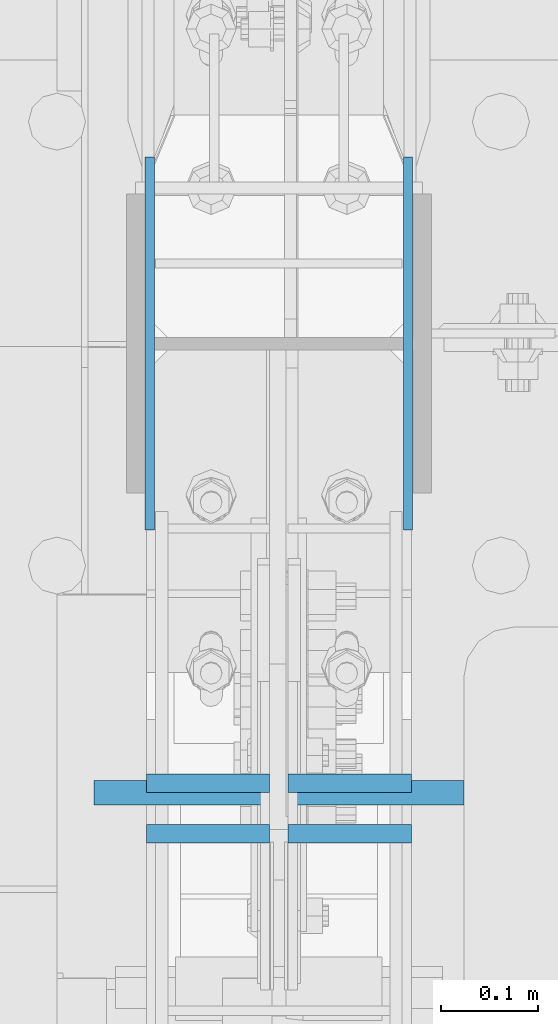
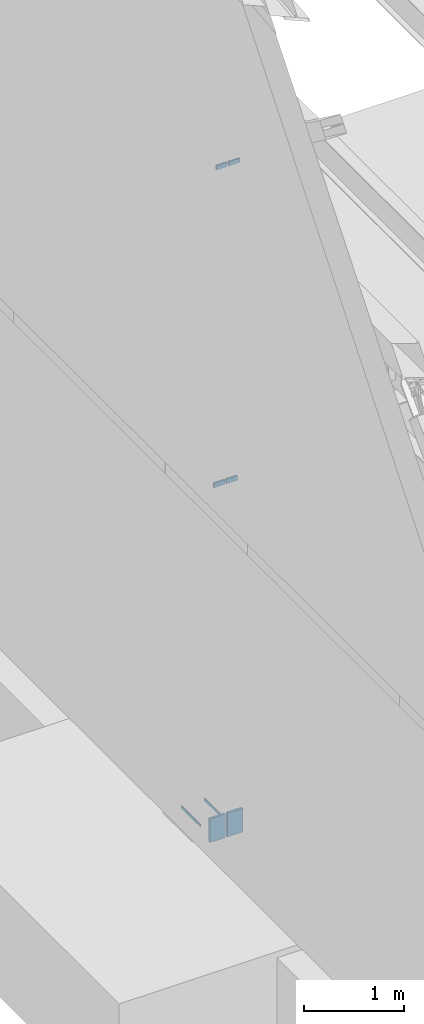
# One storey, part 418 of 1179: 8 columns, 3 elements without a shape of their own.
"""IFC2X3 building model written with IfcOpenShell, lengths in millimetres."""

from ifc_helpers import new_model, si_unit, frame, origin_with_axes, place, context, subcontext, project, spatial, faceted_brep, material, type_object, element, aggregate, save


model = new_model("IFC2X3")

# Units and contexts
model_context = context("Model", 3, precision=1e-05, world=origin_with_axes())
body_context = subcontext(model_context, "Body", "Model", "MODEL_VIEW")
ifc_project = project(units=[si_unit("LENGTHUNIT", "METRE", prefix="MILLI"), si_unit("AREAUNIT", "SQUARE_METRE"), si_unit("VOLUMEUNIT", "CUBIC_METRE"), si_unit("MASSUNIT", "GRAM", prefix="KILO"), si_unit("TIMEUNIT", "SECOND"), si_unit("PLANEANGLEUNIT", "RADIAN"), si_unit("SOLIDANGLEUNIT", "STERADIAN"), si_unit("THERMODYNAMICTEMPERATUREUNIT", "DEGREE_CELSIUS"), si_unit("LUMINOUSINTENSITYUNIT", "LUMEN")], contexts=[model_context])

# Site, building, storey
site_placement = place(None, origin_with_axes())
site = spatial("IfcSite", under=ifc_project, at=site_placement, CompositionType="ELEMENT")
building_placement = place(site_placement, origin_with_axes())
building = spatial("IfcBuilding", under=site, at=building_placement, Name="Undefined", CompositionType="ELEMENT")
storey_placement = place(building_placement, origin_with_axes())
storey = spatial("IfcBuildingStorey", under=building, at=storey_placement, Name="Undefined", CompositionType="ELEMENT", Elevation=0.0)

# Assembly, columns
assembly_1_placement = place(storey_placement, origin_with_axes())
assembly_1 = element("IfcElementAssembly", 1, at=assembly_1_placement, inside=storey, Name="COLUMN", AssemblyPlace="NOTDEFINED", PredefinedType="RIGID_FRAME")
ifc_material = material(Name="STEEL/A572-GR.50")
column_type_1 = type_object("IfcColumnType", PredefinedType="NOTDEFINED")
column_1_placement = place(assembly_1_placement, frame((564.753000000002, 19227.8, -215.9), z_axis=(0.0, -1.0, 0.0), x_axis=(0.0, 0.0, 1.0)))
column_1 = element("IfcColumn", 2, at=column_1_placement, type_object=column_type_1, material=ifc_material, Name="PLATE", context=body_context, shape_type="Brep", body=[
    faceted_brep([(0.0, 4.76249999999982, -192.087500000001), (0.0, 4.76249999999982, 192.0875), (31.75, 4.76249999999982, 192.0875), (31.75, 4.76249999999982, -192.087500000001), (0.0, -4.76249999999982, 192.0875), (31.75, -4.76249999999982, 192.0875), (0.0, -4.76249999999982, -192.087500000001), (31.75, -4.76249999999982, -192.087500000001)], [[[0, 1, 2, 3]], [[1, 4, 5, 2]], [[4, 6, 7, 5]], [[6, 0, 3, 7]], [[5, 7, 3, 2]], [[6, 4, 1, 0]]]),
])
column_2_placement = place(assembly_1_placement, frame((298.846874999999, 19227.8, -215.9), z_axis=(0.0, -1.0, 0.0), x_axis=(0.0, 0.0, 1.0)))
column_2 = element("IfcColumn", 3, at=column_2_placement, type_object=column_type_1, material=ifc_material, Name="PLATE", context=body_context, shape_type="Brep", body=[
    faceted_brep([(0.0, 4.76249999999982, -192.087500000001), (0.0, 4.76249999999982, 192.0875), (31.75, 4.76249999999982, 192.0875), (31.75, 4.76249999999982, -192.087500000001), (0.0, -4.76249999999982, 192.0875), (31.75, -4.76249999999982, 192.0875), (0.0, -4.76249999999982, -192.087500000001), (31.75, -4.76249999999982, -192.087500000001)], [[[0, 1, 2, 3]], [[1, 4, 5, 2]], [[4, 6, 7, 5]], [[6, 0, 3, 7]], [[5, 7, 3, 2]], [[6, 4, 1, 0]]]),
])
column_type_2 = type_object("IfcColumnType", PredefinedType="NOTDEFINED")
column_3_placement = place(assembly_1_placement, frame((358.774999999999, 18723.1498035139, 8026.4), z_axis=(-1.0, 0.0, 0.0), x_axis=(0.0, 0.0, 1.0)))
column_3 = element("IfcColumn", 4, at=column_3_placement, type_object=column_type_2, material=ifc_material, Name="PLATE", context=body_context, shape_type="Brep", body=[
    faceted_brep([(0.0, 9.52500000000146, -63.5), (0.0, 9.52500000000146, 63.5), (50.8000000000002, 9.52500000000146, 63.5), (50.8000000000002, 9.52500000000146, -63.5), (0.0, -9.52500000000146, 63.5), (50.8000000000002, -9.52500000000146, 63.5), (0.0, -9.52500000000146, -63.5), (50.8000000000002, -9.52500000000146, -63.5)], [[[0, 1, 2, 3]], [[1, 4, 5, 2]], [[4, 6, 7, 5]], [[6, 0, 3, 7]], [[5, 7, 3, 2]], [[6, 4, 1, 0]]]),
])
column_4_placement = place(assembly_1_placement, frame((504.824999999999, 18723.1498035139, 8026.4), z_axis=(-1.0, 0.0, 0.0), x_axis=(0.0, 0.0, 1.0)))
column_4 = element("IfcColumn", 5, at=column_4_placement, type_object=column_type_2, material=ifc_material, Name="PLATE", context=body_context, shape_type="Brep", body=[
    faceted_brep([(0.0, 9.52500000000146, -63.5), (0.0, 9.52500000000146, 63.5), (50.8000000000002, 9.52500000000146, 63.5), (50.8000000000002, 9.52500000000146, -63.5), (0.0, -9.52500000000146, 63.5), (50.8000000000002, -9.52500000000146, 63.5), (0.0, -9.52500000000146, -63.5), (50.8000000000002, -9.52500000000146, -63.5)], [[[0, 1, 2, 3]], [[1, 4, 5, 2]], [[4, 6, 7, 5]], [[6, 0, 3, 7]], [[5, 7, 3, 2]], [[6, 4, 1, 0]]]),
])

# Assembly, column
assembly_2_placement = place(storey_placement, origin_with_axes())
assembly_2 = element("IfcElementAssembly", 6, at=assembly_2_placement, inside=storey, Name="PLATE", AssemblyPlace="NOTDEFINED", PredefinedType="RIGID_FRAME")
column_type_3 = type_object("IfcColumnType", PredefinedType="NOTDEFINED")
column_5_placement = place(assembly_2_placement, frame((330.2, 18765.3668875637, -215.9), z_axis=(1.0, 0.0, 0.0), x_axis=(0.0, 0.0, 1.0)))
column_5 = element("IfcColumn", 7, at=column_5_placement, type_object=column_type_3, material=ifc_material, Name="PLATE", context=body_context, shape_type="Brep", body=[
    faceted_brep([(0.0, 12.6999999999998, -88.9000000000015), (0.0, 12.6999999999998, 88.9000000000015), (292.287947617165, 12.7000000000007, 88.9000000000015), (292.287947617165, 12.7000000000007, -88.9000000000015), (0.0, -12.6999999999998, 88.9000000000015), (292.287947617165, -12.7000000000007, 88.9000000000015), (0.0, -12.6999999999998, -88.9000000000015), (292.287947617165, -12.7000000000007, -88.9000000000015)], [[[0, 1, 2, 3]], [[1, 4, 5, 2]], [[4, 6, 7, 5]], [[6, 0, 3, 7]], [[5, 7, 3, 2]], [[6, 4, 1, 0]]]),
])
aggregate(assembly_2, [column_5])

assembly_3_placement = place(storey_placement, origin_with_axes())
assembly_3 = element("IfcElementAssembly", 8, at=assembly_3_placement, inside=storey, Name="PLATE", AssemblyPlace="NOTDEFINED", PredefinedType="RIGID_FRAME")
column_6_placement = place(assembly_3_placement, frame((533.4, 18765.3668875637, -215.9), z_axis=(-1.0, 0.0, 0.0), x_axis=(0.0, 0.0, 1.0)))
column_6 = element("IfcColumn", 9, at=column_6_placement, type_object=column_type_3, material=ifc_material, Name="PLATE", context=body_context, shape_type="Brep", body=[
    faceted_brep([(0.0, 12.6999999999998, -88.9000000000015), (0.0, 12.6999999999998, 88.9000000000015), (292.287947617165, 12.7000000000007, 88.9000000000015), (292.287947617165, 12.7000000000007, -88.9000000000015), (0.0, -12.6999999999998, 88.9000000000015), (292.287947617165, -12.7000000000007, 88.9000000000015), (0.0, -12.6999999999998, -88.9000000000015), (292.287947617165, -12.7000000000007, -88.9000000000015)], [[[0, 1, 2, 3]], [[1, 4, 5, 2]], [[4, 6, 7, 5]], [[6, 0, 3, 7]], [[5, 7, 3, 2]], [[6, 4, 1, 0]]]),
])
aggregate(assembly_3, [column_6])

# Column
column_type_4 = type_object("IfcColumnType", PredefinedType="NOTDEFINED")
column_7_placement = place(assembly_1_placement, frame((358.775000000002, 18775.0265696625, 4102.1), z_axis=(1.0, 0.0, 0.0), x_axis=(0.0, 0.0, 1.0)))
column_7 = element("IfcColumn", 10, at=column_7_placement, type_object=column_type_4, material=ifc_material, Name="PLATE", context=body_context, shape_type="Brep", body=[
    faceted_brep([(0.0, 9.52500000000146, -63.5), (0.0, 9.52500000000146, 63.5), (56.4906928705395, 9.52499999999964, 63.5), (56.4906928705395, 9.52499999999964, -63.5), (0.0, -9.52500000000146, 63.5), (56.4906928705395, -9.52499999999964, 63.5), (0.0, -9.52500000000146, -63.5), (56.4906928705395, -9.52499999999964, -63.5)], [[[0, 1, 2, 3]], [[1, 4, 5, 2]], [[4, 6, 7, 5]], [[6, 0, 3, 7]], [[5, 7, 3, 2]], [[6, 4, 1, 0]]]),
])

column_8_placement = place(assembly_1_placement, frame((504.824713611823, 18775.0265696625, 4102.1), z_axis=(-1.0, 0.0, 0.0), x_axis=(0.0, 0.0, 1.0)))
column_8 = element("IfcColumn", 11, at=column_8_placement, type_object=column_type_4, material=ifc_material, Name="PLATE", context=body_context, shape_type="Brep", body=[
    faceted_brep([(0.0, 9.52500000000146, -63.5), (0.0, 9.52500000000146, 63.5), (56.4906928705395, 9.52499999999964, 63.5), (56.4906928705395, 9.52499999999964, -63.5), (0.0, -9.52500000000146, 63.5), (56.4906928705395, -9.52499999999964, 63.5), (0.0, -9.52500000000146, -63.5), (56.4906928705395, -9.52499999999964, -63.5)], [[[0, 1, 2, 3]], [[1, 4, 5, 2]], [[4, 6, 7, 5]], [[6, 0, 3, 7]], [[5, 7, 3, 2]], [[6, 4, 1, 0]]]),
])

aggregate(assembly_1, [column_1, column_2, column_3, column_4, column_7, column_8])

save(model, "model.ifc")
